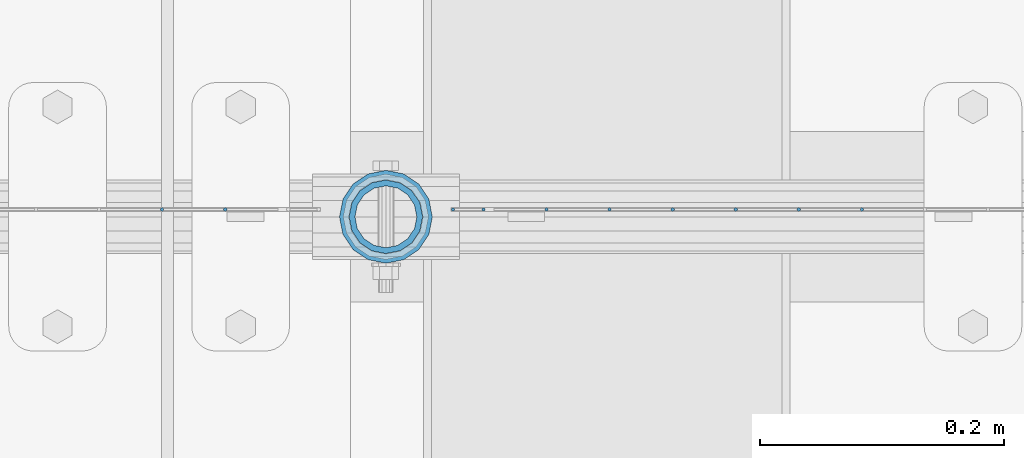
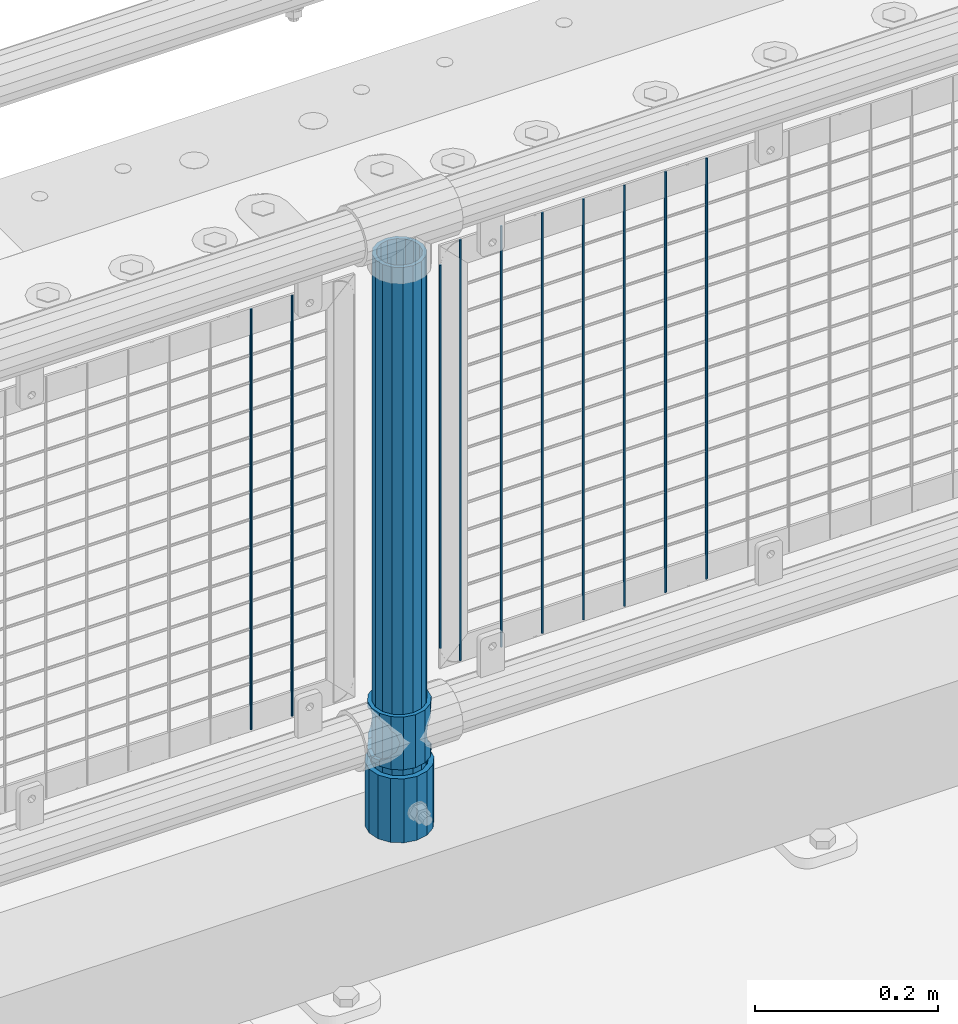
# One storey, part 75 of 193: 13 columns.
"""IFC2X3 building model written with IfcOpenShell, lengths in millimetres."""

from ifc_helpers import new_model, si_unit, frame, origin_with_axes, place, context, subcontext, project, spatial, faceted_brep, material, type_object, element, save


model = new_model("IFC2X3")

# Units and contexts
model_context = context("Model", 3, precision=1e-05, world=origin_with_axes())
body_context = subcontext(model_context, "Body", "Model", "MODEL_VIEW")
ifc_project = project(units=[si_unit("LENGTHUNIT", "METRE", prefix="MILLI"), si_unit("AREAUNIT", "SQUARE_METRE"), si_unit("VOLUMEUNIT", "CUBIC_METRE"), si_unit("MASSUNIT", "GRAM", prefix="KILO"), si_unit("TIMEUNIT", "SECOND"), si_unit("PLANEANGLEUNIT", "RADIAN"), si_unit("SOLIDANGLEUNIT", "STERADIAN"), si_unit("THERMODYNAMICTEMPERATUREUNIT", "DEGREE_CELSIUS"), si_unit("LUMINOUSINTENSITYUNIT", "LUMEN")], contexts=[model_context])

# Site, building, storey
site_placement = place(None, origin_with_axes())
site = spatial("IfcSite", under=ifc_project, at=site_placement, CompositionType="ELEMENT")
building_placement = place(site_placement, origin_with_axes())
building = spatial("IfcBuilding", under=site, at=building_placement, Name="Standard", CompositionType="ELEMENT")
storey_placement = place(building_placement, origin_with_axes())
storey = spatial("IfcBuildingStorey", under=building, at=storey_placement, Name="Undefined", CompositionType="ELEMENT", Elevation=0.0)

# Columns
ifc_material_1 = material(Name="Misc_Undefined")
column_type_1 = type_object("IfcColumnType", PredefinedType="NOTDEFINED")
column_1_placement = place(storey_placement, frame((-31881.0, 28664.5, 263.020000000001), z_axis=(-1.0, 0.0, 0.0), x_axis=(0.0, 0.0, 1.0)))
element("IfcColumn", 1, at=column_1_placement, inside=storey, type_object=column_type_1, material=ifc_material_1, context=body_context, shape_type="Brep", body=[
    faceted_brep([(56.6106908090114, 21.46069080901, -21.46069080901), (56.6106908090114, 21.46069080901, -27.1226768591041), (61.9623795176744, 13.4513226476338, -32.4743655677703), (63.1897438117172, 11.614442172282, -32.8397438117245), (63.1897438117172, 11.614442172282, -28.0397438117179), (46.7644421722801, 28.0397438117179, -11.614442172282), (46.7644421722801, 28.0397438117179, -20.0882031229849), (51.5310424080006, 24.8548033587067, -24.8548033587067), (35.1500000000015, 30.35, 0.0), (35.1499999999996, 30.3499999999985, -16.6306603983685), (23.5355578277192, 28.0397438117179, -11.614442172282), (23.5355578277192, 28.0397438117179, -20.0882031229849), (13.6893091909879, 21.46069080901, -21.46069080901), (13.6893091909879, 21.46069080901, -27.1226768591041), (18.7689575919987, 24.8548033587067, -24.8548033587067), (7.11025618828211, 11.614442172282, -28.0397438117179), (7.11025618828211, 11.614442172282, -32.8397438117245), (8.33762048232262, 13.4513226476338, -32.4743655677703), (4.79999999999961, 0.0, -30.3499999999985), (4.79999999999961, 0.0, -35.1500000000015), (7.11025618828211, -11.614442172282, -28.0397438117179), (7.11025618828211, -11.614442172282, -32.8397438117172), (13.6893091909879, -21.46069080901, -21.46069080901), (13.6893091909879, -21.46069080901, -27.1226768591114), (8.33762048232484, -13.4513226476338, -32.4743655677703), (23.5355578277191, -28.0397438117179, -11.614442172282), (23.5355578277191, -28.0397438117179, -20.0882031229812), (18.7689575919921, -24.8548033587067, -24.8548033587067), (35.1500000000015, -30.35, 0.0), (35.1499999999996, -30.3499999999985, -16.6306603983721), (46.7644421722801, -28.0397438117179, -11.614442172282), (46.7644421722801, -28.0397438117179, -20.0882031229812), (56.6106908090114, -21.46069080901, -21.46069080901), (56.6106908090114, -21.46069080901, -27.1226768591114), (51.5310424080006, -24.8548033587067, -24.8548033587067), (63.1897438117172, -11.614442172282, -28.0397438117179), (63.1897438117172, -11.614442172282, -32.8397438117172), (61.9623795176767, -13.4513226476338, -32.4743655677703), (65.4999999999997, 0.0, -30.3499999999985), (65.4999999999997, 0.0, -35.1500000000015), (0.0, -28.0397438117179, -11.614442172282), (0.0, -30.3499999999985, 0.0), (0.0, -21.46069080901, -21.46069080901), (0.0, -11.614442172282, -28.0397438117179), (0.0, 0.0, -30.3499999999985), (0.0, 11.614442172282, -28.0397438117179), (0.0, 21.46069080901, -21.46069080901), (0.0, 28.0397438117179, -11.614442172282), (0.0, 30.3499999999985, 0.0), (0.0, 28.0397438117179, 11.614442172282), (23.5355578277192, 28.0397438117179, 11.614442172282), (0.0, 21.46069080901, 21.46069080901), (13.6893091909879, 21.46069080901, 21.46069080901), (0.0, 11.614442172282, 28.0397438117179), (7.11025618828211, 11.614442172282, 28.0397438117179), (0.0, 0.0, 30.3499999999985), (4.79999999999961, 0.0, 30.3499999999985), (0.0, -11.614442172282, 28.0397438117179), (7.11025618828205, -11.614442172282, 28.0397438117179), (0.0, -21.46069080901, 21.46069080901), (13.6893091909879, -21.46069080901, 21.46069080901), (0.0, -28.0397438117179, 11.614442172282), (23.5355578277191, -28.0397438117179, 11.614442172282), (0.0, -32.4743655677703, 13.4513226476338), (0.0, -35.1500000000015, 0.0), (70.2999999999993, -35.1500000000015, 0.0), (70.2999999999993, -32.4743655677703, 13.4513226476338), (0.0, 13.4513226476338, -32.4743655677703), (0.0, 24.8548033587067, -24.8548033587067), (0.0, 0.0, -35.1500000000015), (0.0, -13.4513226476338, -32.4743655677703), (0.0, -24.8548033587067, -24.8548033587067), (0.0, -24.8548033587067, 24.8548033587067), (0.0, -13.4513226476338, 32.4743655677703), (0.0, 0.0, 35.1500000000015), (0.0, 13.4513226476338, 32.4743655677703), (0.0, 24.8548033587067, 24.8548033587067), (0.0, 32.4743655677703, 13.4513226476338), (0.0, 35.1500000000015, 0.0), (0.0, 32.4743655677703, -13.4513226476338), (0.0, -32.4743655677703, -13.4513226476338), (70.2999999999993, 32.4743655677703, 13.4513226476338), (70.2999999999993, 35.1500000000015, 0.0), (70.2999999999993, 32.4743655677703, -13.4513226476338), (70.2999999999993, 24.8548033587067, -24.8548033587067), (70.2999999999993, 13.4513226476338, -32.4743655677703), (70.2999999999993, 0.0, -35.1500000000015), (70.2999999999993, -13.4513226476338, -32.4743655677703), (70.2999999999993, -24.8548033587067, -24.8548033587067), (70.2999999999993, -32.4743655677703, -13.4513226476338), (70.2999999999993, 28.0397438117179, 11.614442172282), (70.2999999999993, 21.46069080901, 21.46069080901), (56.6106908090114, 21.46069080901, 21.46069080901), (46.7644421722801, 28.0397438117179, 11.614442172282), (70.2999999999993, 11.614442172282, 28.0397438117179), (63.1897438117172, 11.614442172282, 28.0397438117179), (70.2999999999993, 0.0, 30.3499999999985), (65.4999999999997, 0.0, 30.3499999999985), (70.2999999999993, -11.614442172282, 28.0397438117179), (63.1897438117172, -11.614442172282, 28.0397438117179), (70.2999999999993, -21.46069080901, 21.46069080901), (56.6106908090114, -21.46069080901, 21.46069080901), (70.2999999999993, -28.0397438117179, 11.614442172282), (46.7644421722801, -28.0397438117179, 11.614442172282), (70.2999999999993, -11.614442172282, -28.0397438117179), (70.2999999999993, 0.0, -30.3499999999985), (70.2999999999993, -21.46069080901, -21.46069080901), (70.2999999999993, -28.0397438117179, -11.614442172282), (70.2999999999993, -30.3499999999985, 0.0), (70.2999999999993, 24.8548033587067, 24.8548033587067), (70.2999999999993, 13.4513226476338, 32.4743655677703), (70.2999999999993, 0.0, 35.1500000000015), (70.2999999999993, -13.4513226476338, 32.4743655677703), (70.2999999999993, -24.8548033587067, 24.8548033587067), (70.2999999999993, 30.3499999999985, 0.0), (70.2999999999993, 28.0397438117179, -11.614442172282), (70.2999999999993, 21.46069080901, -21.46069080901), (70.2999999999993, 11.614442172282, -28.0397438117179), (61.9623795176742, 13.4513226476338, 32.4743655677703), (51.5310424080006, 24.8548033587067, 24.8548033587067), (56.6106908090114, 21.46069080901, 27.1226768591077), (65.4999999999997, 0.0, 35.1500000000015), (63.1897438117172, 11.614442172282, 32.8397438117136), (63.1897438117172, -11.614442172282, 32.8397438117136), (61.9623795176767, -13.4513226476338, 32.4743655677703), (56.6106908090114, -21.46069080901, 27.1226768591041), (51.5310424080006, -24.8548033587067, 24.8548033587067), (18.7689575919921, -24.8548033587067, 24.8548033587067), (46.7644421722801, -28.0397438117179, 20.0882031229812), (35.1499999999996, -30.3499999999985, 16.6306603983685), (23.5355578277191, -28.0397438117179, 20.0882031229812), (8.33762048232512, -13.4513226476338, 32.4743655677703), (13.6893091909879, -21.46069080901, 27.1226768591041), (4.79999999999961, 0.0, 35.1500000000015), (7.11025618828205, -11.614442172282, 32.8397438117136), (7.11025618828211, 11.614442172282, 32.8397438117136), (8.3376204823229, 13.4513226476338, 32.4743655677703), (13.6893091909879, 21.46069080901, 27.1226768591077), (18.7689575919987, 24.8548033587067, 24.8548033587067), (23.5355578277192, 28.0397438117179, 20.0882031229739), (35.1499999999996, 30.3499999999985, 16.6306603983576), (46.7644421722801, 28.0397438117179, 20.0882031229739)], [[[0, 1, 2, 3, 4]], [[5, 6, 7, 1, 0]], [[8, 9, 6, 5]], [[10, 11, 9, 8]], [[12, 13, 14, 11, 10]], [[15, 16, 17, 13, 12]], [[18, 19, 16, 15]], [[20, 21, 19, 18]], [[22, 23, 24, 21, 20]], [[25, 26, 27, 23, 22]], [[28, 29, 26, 25]], [[30, 31, 29, 28]], [[32, 33, 34, 31, 30]], [[35, 36, 37, 33, 32]], [[38, 39, 36, 35]], [[4, 3, 39, 38]], [[40, 41, 28, 25]], [[42, 40, 25, 22]], [[43, 42, 22, 20]], [[44, 43, 20, 18]], [[45, 44, 18, 15]], [[46, 45, 15, 12]], [[47, 46, 12, 10]], [[48, 47, 10, 8]], [[49, 48, 8, 50]], [[51, 49, 50, 52]], [[53, 51, 52, 54]], [[55, 53, 54, 56]], [[57, 55, 56, 58]], [[59, 57, 58, 60]], [[61, 59, 60, 62]], [[41, 61, 62, 28]], [[63, 64, 65, 66]], [[17, 67, 68, 14, 13]], [[19, 69, 67, 17, 16]], [[70, 69, 19, 21, 24]], [[71, 70, 24, 23, 27]], [[63, 72, 73, 74, 75, 76, 77, 78, 79, 68, 67, 69, 70, 71, 80, 64], [40, 42, 43, 44, 45, 46, 47, 48, 49, 51, 53, 55, 57, 59, 61, 41]], [[78, 77, 81, 82]], [[79, 78, 82, 83]], [[14, 68, 79, 83, 84, 7, 6, 9, 11]], [[84, 85, 2, 1, 7]], [[85, 86, 39, 3, 2]], [[37, 87, 88, 34, 33]], [[39, 86, 87, 37, 36]], [[34, 88, 89, 80, 71, 27, 26, 29, 31]], [[64, 80, 89, 65]], [[90, 91, 92, 93]], [[91, 94, 95, 92]], [[94, 96, 97, 95]], [[96, 98, 99, 97]], [[98, 100, 101, 99]], [[100, 102, 103, 101]], [[104, 105, 38, 35]], [[106, 104, 35, 32]], [[107, 106, 32, 30]], [[108, 107, 30, 28]], [[102, 108, 28, 103]], [[88, 87, 86, 85, 84, 83, 82, 81, 109, 110, 111, 112, 113, 66, 65, 89], [100, 98, 96, 94, 91, 90, 114, 115, 116, 117, 105, 104, 106, 107, 108, 102]], [[118, 110, 109, 119, 120]], [[121, 111, 110, 118, 122]], [[112, 111, 121, 123, 124]], [[113, 112, 124, 125, 126]], [[127, 72, 63, 66, 113, 126, 128, 129, 130]], [[131, 73, 72, 127, 132]], [[133, 74, 73, 131, 134]], [[75, 74, 133, 135, 136]], [[76, 75, 136, 137, 138]], [[119, 109, 81, 77, 76, 138, 139, 140, 141]], [[92, 120, 119, 141, 93]], [[95, 122, 118, 120, 92]], [[97, 121, 122, 95]], [[99, 123, 121, 97]], [[101, 125, 124, 123, 99]], [[103, 128, 126, 125, 101]], [[28, 129, 128, 103]], [[62, 130, 129, 28]], [[60, 132, 127, 130, 62]], [[58, 134, 131, 132, 60]], [[56, 133, 134, 58]], [[54, 135, 133, 56]], [[52, 137, 136, 135, 54]], [[50, 139, 138, 137, 52]], [[8, 140, 139, 50]], [[93, 141, 140, 8]], [[114, 90, 93, 8]], [[115, 114, 8, 5]], [[116, 115, 5, 0]], [[117, 116, 0, 4]], [[105, 117, 4, 38]]]),
])
ifc_material_2 = material()
column_type_2 = type_object("IfcColumnType", PredefinedType="NOTDEFINED")
column_2_placement = place(storey_placement, frame((-31881.0, 28664.5, 168.02), z_axis=(-1.0, 0.0, 0.0), x_axis=(0.0, 0.0, 1.0)))
element("IfcColumn", 2, at=column_2_placement, inside=storey, type_object=column_type_2, material=ifc_material_2, context=body_context, shape_type="Brep", body=[
    faceted_brep([(0.0, -25.3499999999985, 0.0), (0.0, -23.4203461491597, 9.70102501045403), (760.0, -23.4203461491597, 9.70102501045403), (760.0, -25.3499999999985, 0.0), (0.0, -17.9251569030785, 17.9251569030785), (760.0, -17.9251569030785, 17.9251569030785), (0.0, -9.70102501045403, 23.4203461491597), (760.0, -9.70102501045403, 23.4203461491597), (0.0, 0.0, 25.3499999999985), (760.0, 0.0, 25.3499999999985), (0.0, 9.70102501045403, 23.4203461491597), (760.0, 9.70102501045403, 23.4203461491597), (0.0, 17.9251569030785, 17.9251569030785), (760.0, 17.9251569030785, 17.9251569030785), (0.0, 23.4203461491597, 9.70102501045403), (760.0, 23.4203461491597, 9.70102501045403), (0.0, 25.3499999999985, 0.0), (760.0, 25.3499999999985, 0.0), (0.0, 23.4203461491597, -9.70102501045403), (760.0, 23.4203461491597, -9.70102501045403), (0.0, 17.9251569030785, -17.9251569030785), (760.0, 17.9251569030785, -17.9251569030785), (0.0, 9.70102501045403, -23.4203461491597), (760.0, 9.70102501045403, -23.4203461491597), (0.0, 0.0, -25.3499999999985), (760.0, 0.0, -25.3499999999985), (0.0, -9.70102501045403, -23.4203461491597), (760.0, -9.70102501045403, -23.4203461491597), (0.0, -17.9251569030785, -17.9251569030785), (760.0, -17.9251569030785, -17.9251569030785), (0.0, -23.4203461491597, -9.70102501045403), (760.0, -23.4203461491597, -9.70102501045403), (0.0, -30.1500000000015, 0.0), (0.0, -27.8549679052157, -11.5379054858058), (760.0, -27.8549679052157, -11.5379054858058), (760.0, -30.1500000000015, 0.0), (0.0, -21.3192694527752, -21.3192694527752), (760.0, -21.3192694527752, -21.3192694527752), (0.0, -11.5379054858058, -27.8549679052157), (760.0, -11.5379054858058, -27.8549679052157), (0.0, 0.0, -30.1500000000015), (760.0, 0.0, -30.1500000000015), (0.0, 11.5379054858058, -27.8549679052157), (760.0, 11.5379054858058, -27.8549679052157), (0.0, 21.3192694527752, -21.3192694527752), (760.0, 21.3192694527752, -21.3192694527752), (0.0, 27.8549679052157, -11.5379054858058), (760.0, 27.8549679052157, -11.5379054858058), (0.0, 30.1500000000015, 0.0), (760.0, 30.1500000000015, 0.0), (0.0, 27.8549679052157, 11.5379054858058), (760.0, 27.8549679052157, 11.5379054858058), (0.0, 21.3192694527752, 21.3192694527752), (760.0, 21.3192694527752, 21.3192694527752), (0.0, 11.5379054858058, 27.8549679052157), (760.0, 11.5379054858058, 27.8549679052157), (0.0, 0.0, 30.1500000000015), (760.0, 0.0, 30.1500000000015), (0.0, -11.5379054858058, 27.8549679052157), (760.0, -11.5379054858058, 27.8549679052157), (0.0, -21.3192694527752, 21.3192694527752), (760.0, -21.3192694527752, 21.3192694527752), (0.0, -27.8549679052157, 11.5379054858058), (760.0, -27.8549679052157, 11.5379054858058)], [[[0, 1, 2, 3]], [[1, 4, 5, 2]], [[4, 6, 7, 5]], [[6, 8, 9, 7]], [[8, 10, 11, 9]], [[10, 12, 13, 11]], [[12, 14, 15, 13]], [[14, 16, 17, 15]], [[16, 18, 19, 17]], [[18, 20, 21, 19]], [[20, 22, 23, 21]], [[22, 24, 25, 23]], [[24, 26, 27, 25]], [[26, 28, 29, 27]], [[28, 30, 31, 29]], [[30, 0, 3, 31]], [[32, 33, 34, 35]], [[33, 36, 37, 34]], [[36, 38, 39, 37]], [[38, 40, 41, 39]], [[40, 42, 43, 41]], [[42, 44, 45, 43]], [[44, 46, 47, 45]], [[46, 48, 49, 47]], [[48, 50, 51, 49]], [[50, 52, 53, 51]], [[52, 54, 55, 53]], [[54, 56, 57, 55]], [[56, 58, 59, 57]], [[58, 60, 61, 59]], [[60, 62, 63, 61]], [[62, 32, 35, 63]], [[37, 39, 41, 43, 45, 47, 49, 51, 53, 55, 57, 59, 61, 63, 35, 34], [5, 7, 9, 11, 13, 15, 17, 19, 21, 23, 25, 27, 29, 31, 3, 2]], [[62, 60, 58, 56, 54, 52, 50, 48, 46, 44, 42, 40, 38, 36, 33, 32], [30, 28, 26, 24, 22, 20, 18, 16, 14, 12, 10, 8, 6, 4, 1, 0]]]),
])
column_type_3 = type_object("IfcColumnType", PredefinedType="NOTDEFINED")
column_3_placement = place(storey_placement, frame((-31881.0, 28664.5, 168.02), z_axis=(0.0, 1.0, 0.0), x_axis=(0.0, 0.0, 1.0)))
element("IfcColumn", 3, at=column_3_placement, inside=storey, type_object=column_type_3, material=ifc_material_2, context=body_context, shape_type="Brep", body=[
    faceted_brep([(0.0, -31.75, 0.0), (0.0, -29.3331751572332, 12.1501989775934), (85.0, -29.3331751572332, 12.1501989775934), (85.0, -31.75, 0.0), (0.0, -22.4506403026717, 22.4506403026717), (85.0, -22.4506403026717, 22.4506403026717), (0.0, -12.1501989775934, 29.3331751572332), (85.0, -12.1501989775934, 29.3331751572332), (0.0, 0.0, 31.75), (85.0, 0.0, 31.75), (0.0, 12.1501989775934, 29.3331751572332), (85.0, 12.1501989775934, 29.3331751572332), (0.0, 22.4506403026717, 22.4506403026717), (85.0, 22.4506403026717, 22.4506403026717), (0.0, 29.3331751572332, 12.1501989775934), (85.0, 29.3331751572332, 12.1501989775934), (0.0, 31.75, 0.0), (85.0, 31.75, 0.0), (0.0, 29.3331751572332, -12.1501989775934), (85.0, 29.3331751572332, -12.1501989775934), (0.0, 22.4506403026717, -22.4506403026717), (85.0, 22.4506403026717, -22.4506403026717), (0.0, 12.1501989775934, -29.3331751572332), (85.0, 12.1501989775934, -29.3331751572332), (0.0, 0.0, -31.75), (85.0, 0.0, -31.75), (0.0, -12.1501989775934, -29.3331751572332), (85.0, -12.1501989775934, -29.3331751572332), (0.0, -22.4506403026717, -22.4506403026717), (85.0, -22.4506403026717, -22.4506403026717), (0.0, -29.3331751572332, -12.1501989775934), (85.0, -29.3331751572332, -12.1501989775934), (0.0, -38.0499999999993, 0.0), (0.0, -35.1536162120537, -14.5611046014928), (85.0, -35.1536162120537, -14.5611046014928), (85.0, -38.0499999999993, 0.0), (0.0, -26.9054130241493, -26.9054130241493), (85.0, -26.9054130241493, -26.9054130241493), (0.0, -14.5611046014928, -35.1536162120537), (85.0, -14.5611046014928, -35.1536162120537), (0.0, 0.0, -38.0499999999993), (85.0, 0.0, -38.0499999999993), (0.0, 14.5611046014928, -35.1536162120537), (85.0, 14.5611046014928, -35.1536162120537), (0.0, 26.9054130241493, -26.9054130241493), (85.0, 26.9054130241493, -26.9054130241493), (0.0, 35.1536162120537, -14.5611046014928), (85.0, 35.1536162120537, -14.5611046014928), (0.0, 38.0499999999993, 0.0), (85.0, 38.0499999999993, 0.0), (0.0, 35.1536162120537, 14.5611046014928), (85.0, 35.1536162120537, 14.5611046014928), (0.0, 26.9054130241493, 26.9054130241493), (85.0, 26.9054130241493, 26.9054130241493), (0.0, 14.5611046014928, 35.1536162120537), (85.0, 14.5611046014928, 35.1536162120537), (0.0, 0.0, 38.0499999999993), (85.0, 0.0, 38.0499999999993), (0.0, -14.5611046014928, 35.1536162120537), (85.0, -14.5611046014928, 35.1536162120537), (0.0, -26.9054130241493, 26.9054130241493), (85.0, -26.9054130241493, 26.9054130241493), (0.0, -35.1536162120537, 14.5611046014928), (85.0, -35.1536162120537, 14.5611046014928)], [[[0, 1, 2, 3]], [[1, 4, 5, 2]], [[4, 6, 7, 5]], [[6, 8, 9, 7]], [[8, 10, 11, 9]], [[10, 12, 13, 11]], [[12, 14, 15, 13]], [[14, 16, 17, 15]], [[16, 18, 19, 17]], [[18, 20, 21, 19]], [[20, 22, 23, 21]], [[22, 24, 25, 23]], [[24, 26, 27, 25]], [[26, 28, 29, 27]], [[28, 30, 31, 29]], [[30, 0, 3, 31]], [[32, 33, 34, 35]], [[33, 36, 37, 34]], [[36, 38, 39, 37]], [[38, 40, 41, 39]], [[40, 42, 43, 41]], [[42, 44, 45, 43]], [[44, 46, 47, 45]], [[46, 48, 49, 47]], [[48, 50, 51, 49]], [[50, 52, 53, 51]], [[52, 54, 55, 53]], [[54, 56, 57, 55]], [[56, 58, 59, 57]], [[58, 60, 61, 59]], [[60, 62, 63, 61]], [[62, 32, 35, 63]], [[37, 39, 41, 43, 45, 47, 49, 51, 53, 55, 57, 59, 61, 63, 35, 34], [5, 7, 9, 11, 13, 15, 17, 19, 21, 23, 25, 27, 29, 31, 3, 2]], [[62, 60, 58, 56, 54, 52, 50, 48, 46, 44, 42, 40, 38, 36, 33, 32], [30, 28, 26, 24, 22, 20, 18, 16, 14, 12, 10, 8, 6, 4, 1, 0]]]),
])
column_type_4 = type_object("IfcColumnType", Name="D3", PredefinedType="NOTDEFINED")
for number, where, z_axis, x_axis in (
    (4, (-31491.07, 28670.5, 353.020000000001), (-1.0, 0.0, 0.0), (0.0, 0.0, 1.0)),
    (5, (-31542.725, 28670.5, 353.020000000001), (-1.0, 0.0, 0.0), (0.0, 0.0, 1.0)),
    (6, (-31594.38, 28670.5, 353.020000000001), (-1.0, 0.0, 0.0), (0.0, 0.0, 1.0)),
    (7, (-31646.035, 28670.5, 353.020000000001), (-1.0, 0.0, 0.0), (0.0, 0.0, 1.0)),
    (8, (-31697.69, 28670.5, 353.020000000001), (-1.0, 0.0, 0.0), (0.0, 0.0, 1.0)),
    (9, (-31749.345, 28670.5, 353.020000000001), (-1.0, 0.0, 0.0), (0.0, 0.0, 1.0)),
):
    element("IfcColumn", number, at=place(storey_placement, frame(where, z_axis=z_axis, x_axis=x_axis)), inside=storey, type_object=column_type_4, material=ifc_material_1, ObjectType="D3", context=body_context, shape_type="Brep", body=[
        faceted_brep([(0.0, -1.49999999999636, 3.63797880709171e-12), (0.0, -0.75, -1.29903810567669), (560.0, -0.75, -1.29903810567703), (560.0, -1.5, 0.0), (0.0, 0.75, -1.29903810567669), (560.0, 0.75, -1.29903810567703), (0.0, 1.50000000000364, 7.27595761418343e-12), (560.0, 1.5, 0.0), (0.0, 0.75, 1.29903810567669), (560.0, 0.75, 1.29903810567703), (0.0, -0.75, 1.29903810567669), (560.0, -0.75, 1.29903810567703)], [[[0, 1, 2, 3]], [[1, 4, 5, 2]], [[4, 6, 7, 5]], [[6, 8, 9, 7]], [[8, 10, 11, 9]], [[10, 0, 3, 11]], [[5, 7, 9, 11, 3, 2]], [[10, 8, 6, 4, 1, 0]]]),
    ])
column_4_placement = place(storey_placement, frame((-31826.0, 28670.5, 378.020000000001), z_axis=(-1.0, 0.0, 0.0), x_axis=(0.0, 0.0, 1.0)))
element("IfcColumn", 10, at=column_4_placement, inside=storey, type_object=column_type_4, material=ifc_material_1, ObjectType="D3", context=body_context, shape_type="Brep", body=[
    faceted_brep([(0.0, -1.49999999999636, 3.63797880709171e-12), (0.0, -0.75, -1.29903810567669), (510.0, -0.75, -1.29903810567703), (510.0, -1.5, 0.0), (0.0, 0.75, -1.29903810567669), (510.0, 0.75, -1.29903810567703), (0.0, 1.50000000000364, 7.27595761418343e-12), (510.0, 1.5, 0.0), (0.0, 0.75, 1.29903810567669), (510.0, 0.75, 1.29903810567703), (0.0, -0.75, 1.29903810567669), (510.0, -0.75, 1.29903810567703)], [[[0, 1, 2, 3]], [[1, 4, 5, 2]], [[4, 6, 7, 5]], [[6, 8, 9, 7]], [[8, 10, 11, 9]], [[10, 0, 3, 11]], [[5, 7, 9, 11, 3, 2]], [[10, 8, 6, 4, 1, 0]]]),
])
for number, where, z_axis, x_axis in (
    (11, (-31801.0, 28670.5, 353.020000000001), (-1.0, 0.0, 0.0), (0.0, 0.0, 1.0)),
    (12, (-32012.66, 28670.5, 353.020000000001), (-1.0, 0.0, 0.0), (0.0, 0.0, 1.0)),
    (13, (-32064.315, 28670.5, 353.020000000001), (-1.0, 0.0, 0.0), (0.0, 0.0, 1.0)),
):
    element("IfcColumn", number, at=place(storey_placement, frame(where, z_axis=z_axis, x_axis=x_axis)), inside=storey, type_object=column_type_4, material=ifc_material_1, ObjectType="D3", context=body_context, shape_type="Brep", body=[
        faceted_brep([(0.0, -1.49999999999636, 3.63797880709171e-12), (0.0, -0.75, -1.29903810567669), (560.0, -0.75, -1.29903810567703), (560.0, -1.5, 0.0), (0.0, 0.75, -1.29903810567669), (560.0, 0.75, -1.29903810567703), (0.0, 1.50000000000364, 7.27595761418343e-12), (560.0, 1.5, 0.0), (0.0, 0.75, 1.29903810567669), (560.0, 0.75, 1.29903810567703), (0.0, -0.75, 1.29903810567669), (560.0, -0.75, 1.29903810567703)], [[[0, 1, 2, 3]], [[1, 4, 5, 2]], [[4, 6, 7, 5]], [[6, 8, 9, 7]], [[8, 10, 11, 9]], [[10, 0, 3, 11]], [[5, 7, 9, 11, 3, 2]], [[10, 8, 6, 4, 1, 0]]]),
    ])

save(model, "model.ifc")
